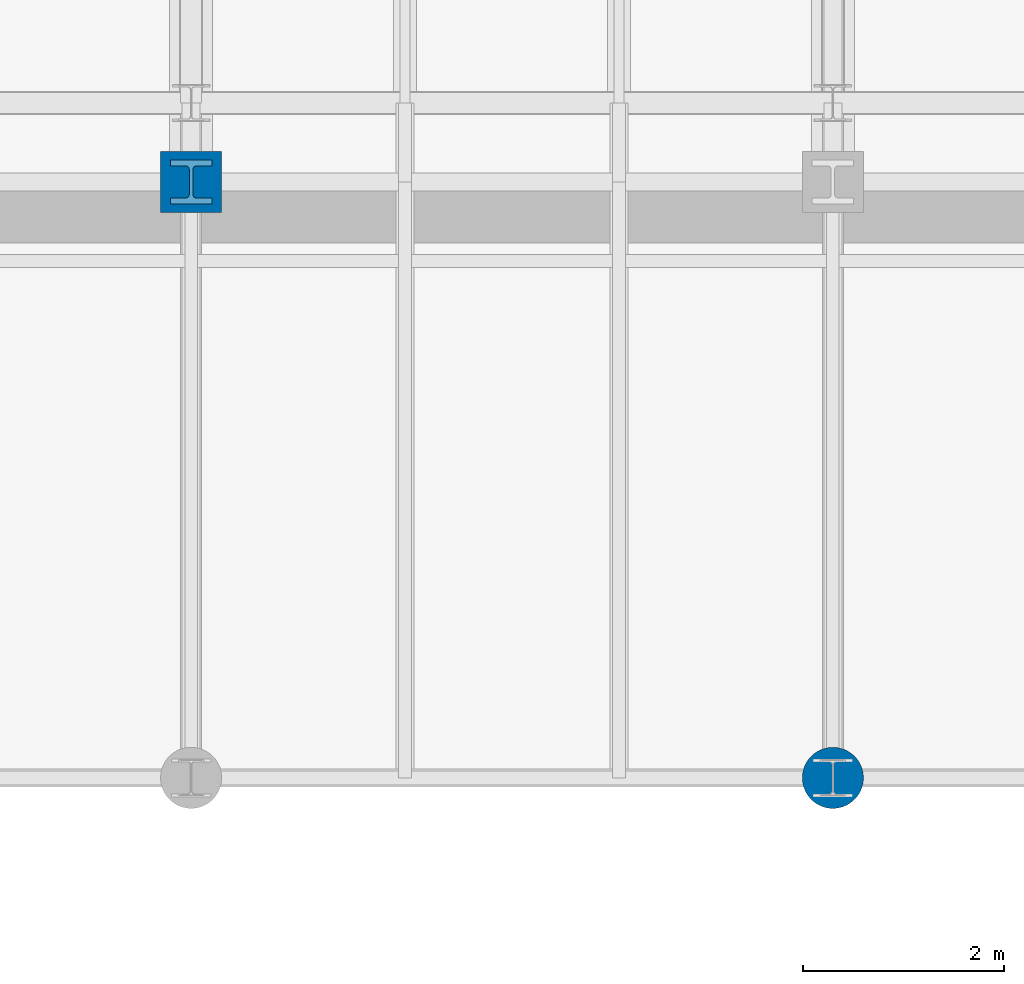
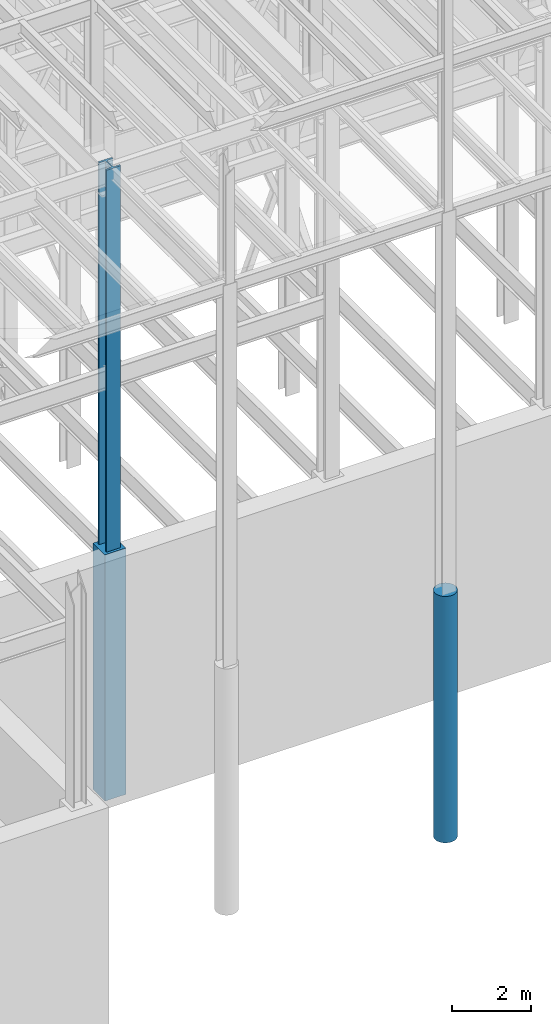
# One storey, part 31 of 150: 3 columns.
"""IFC2X3 building model written with IfcOpenShell, lengths in millimetres."""

from ifc_helpers import new_model, si_unit, frame, origin_with_axes, origin_2d_with_axis, place, context, subcontext, project, spatial, rectangle, circle, i_section, extrude, material, type_object, element, save


model = new_model("IFC2X3")

# Units and contexts
model_context = context("Model", 3, precision=1e-05, world=origin_with_axes())
body_context = subcontext(model_context, "Body", "Model", "MODEL_VIEW")
ifc_project = project(units=[si_unit("LENGTHUNIT", "METRE", prefix="MILLI"), si_unit("AREAUNIT", "SQUARE_METRE"), si_unit("VOLUMEUNIT", "CUBIC_METRE"), si_unit("MASSUNIT", "GRAM", prefix="KILO"), si_unit("TIMEUNIT", "SECOND"), si_unit("PLANEANGLEUNIT", "RADIAN"), si_unit("SOLIDANGLEUNIT", "STERADIAN"), si_unit("THERMODYNAMICTEMPERATUREUNIT", "DEGREE_CELSIUS"), si_unit("LUMINOUSINTENSITYUNIT", "LUMEN")], contexts=[model_context])

# Site, building, storey
site_placement = place(None, origin_with_axes())
site = spatial("IfcSite", under=ifc_project, at=site_placement, CompositionType="ELEMENT")
building_placement = place(site_placement, origin_with_axes())
building = spatial("IfcBuilding", under=site, at=building_placement, Name="Undefined", CompositionType="ELEMENT")
storey_placement = place(building_placement, origin_with_axes())
storey = spatial("IfcBuildingStorey", under=building, at=storey_placement, Name="Undefined", CompositionType="ELEMENT", Elevation=0.0)

# Columns
ifc_material_1 = material(Name="STEEL/A992")
column_type_1 = type_object("IfcColumnType", Name="W14X311", PredefinedType="NOTDEFINED")
column_1_placement = place(storey_placement, frame((50190.4, 9398.0, 22707.6), z_axis=(0.0, 0.0, 1.0), x_axis=(1.0, 0.0, 0.0)))
element("IfcColumn", 1, at=column_1_placement, inside=storey, type_object=column_type_1, material=ifc_material_1, Name="COLUMN", ObjectType="W14X311", context=body_context, shape_type="SweptSolid", body=[
    extrude(i_section(OverallWidth=412.75, OverallDepth=434.975, WebThickness=36.5125, FlangeThickness=57.404, FilletRadius=33.0834, at=origin_2d_with_axis()), frame((0.0, 0.0, 12877.8), z_axis=(0.0, 0.0, -1.0), x_axis=(-1.0, 0.0, 0.0)), (0.0, 0.0, 1.0), 12877.8),
])
ifc_material_2 = material(Name="CONCRETE/5000")
column_type_2 = type_object("IfcColumnType", PredefinedType="NOTDEFINED")
column_2_placement = place(storey_placement, frame((56591.2, 3454.40000000001, 16154.4), z_axis=(0.0, 0.0, 1.0), x_axis=(1.0, 0.0, 0.0)))
element("IfcColumn", 2, at=column_2_placement, inside=storey, type_object=column_type_2, material=ifc_material_2, Name="COLUMN", context=body_context, shape_type="SweptSolid", body=[
    extrude(circle(Radius=304.8, at=origin_2d_with_axis()), frame((0.0, 0.0, 7620.0), z_axis=(0.0, 0.0, -1.0), x_axis=(0.0, -1.0, 0.0)), (0.0, 0.0, 1.0), 7620.0),
])
column_type_3 = type_object("IfcColumnType", PredefinedType="NOTDEFINED")
column_3_placement = place(storey_placement, frame((50190.4, 9398.0, 16154.4), z_axis=(0.0, 0.0, 1.0), x_axis=(1.0, 0.0, 0.0)))
element("IfcColumn", 3, at=column_3_placement, inside=storey, type_object=column_type_3, material=ifc_material_2, Name="COLUMN", context=body_context, shape_type="SweptSolid", body=[
    extrude(rectangle(XDim=609.6, YDim=609.6, at=origin_2d_with_axis()), frame((0.0, 0.0, 7620.0), z_axis=(0.0, 0.0, -1.0), x_axis=(0.0, -1.0, 0.0)), (0.0, 0.0, 1.0), 7620.0),
])

save(model, "model.ifc")
